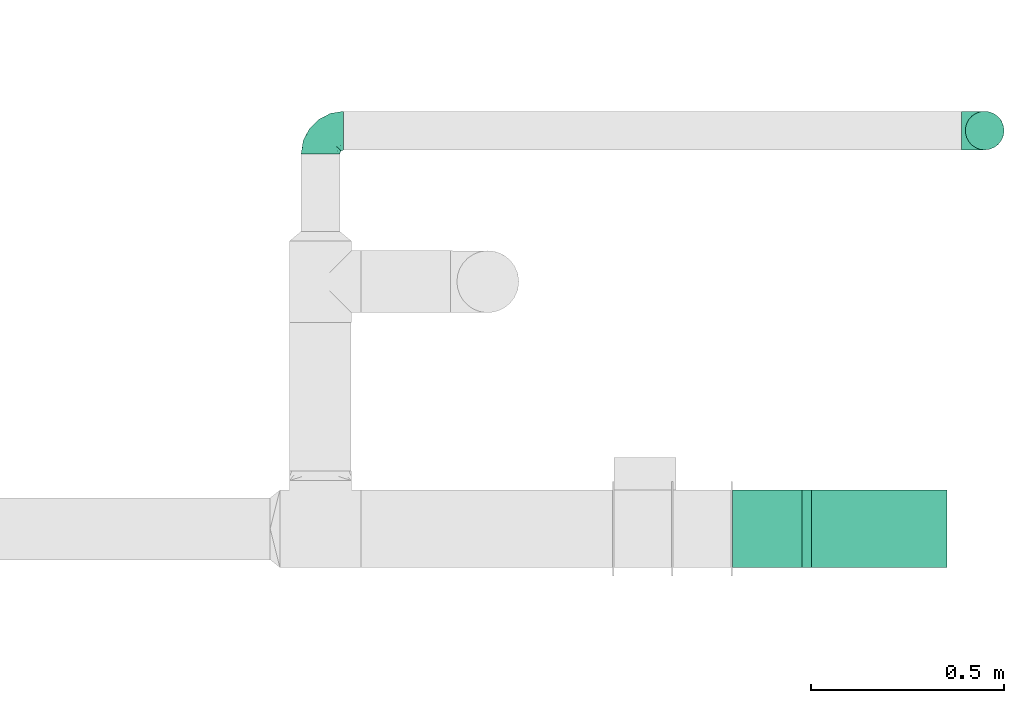
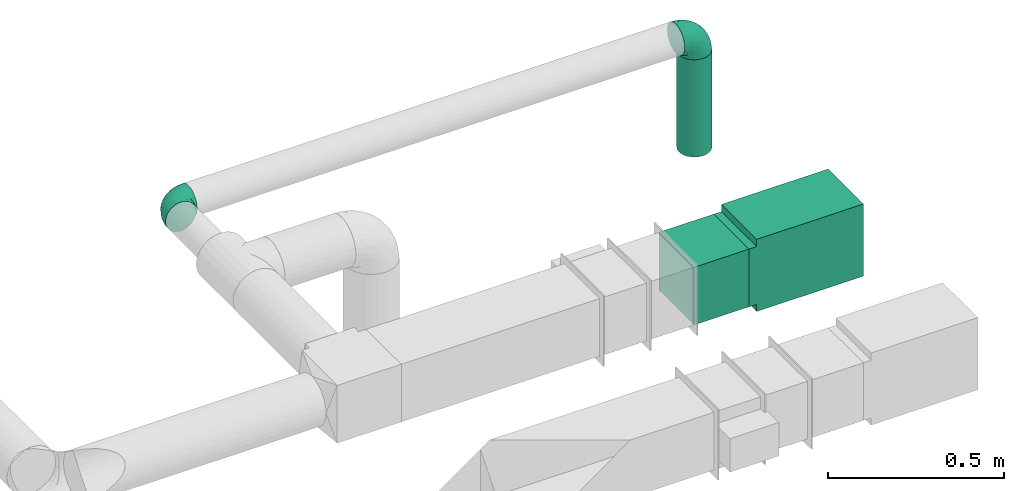
# One storey, part 11 of 12: 3 flow fittings, 2 flow segments.
"""IFC2X3 building model written with IfcOpenShell, lengths in millimetres."""

from ifc_helpers import new_model, entity, si_unit, converted_unit, derived_unit, direction, frame, frame_2d, origin, origin_2d_with_axis, place, context, subcontext, project, spatial, polyline, rectangle, circle, outline, extrude, faceted_brep, source, transform, mapped, type_object, type_shapes, element, save


model = new_model("IFC2X3")

# Units and contexts
model_context = context("Model", 3, precision=0.01, world=origin(), true_north=direction((6.12303176911189e-17, 1.0)))
body_context = subcontext(model_context, "Body", "Model", "MODEL_VIEW")
ifc_project = project(units=[si_unit("LENGTHUNIT", "METRE", prefix="MILLI"), si_unit("AREAUNIT", "SQUARE_METRE"), si_unit("VOLUMEUNIT", "CUBIC_METRE"), converted_unit("PLANEANGLEUNIT", "DEGREE", entity("IfcRatioMeasure", 0.0174532925199433), si_unit("PLANEANGLEUNIT", "RADIAN"), dimensions=[0, 0, 0, 0, 0, 0, 0]), si_unit("MASSUNIT", "GRAM", prefix="KILO"), derived_unit("MASSDENSITYUNIT", [(si_unit("MASSUNIT", "GRAM", prefix="KILO"), 1), (si_unit("LENGTHUNIT", "METRE"), -3)]), si_unit("TIMEUNIT", "SECOND"), si_unit("FREQUENCYUNIT", "HERTZ"), si_unit("THERMODYNAMICTEMPERATUREUNIT", "DEGREE_CELSIUS"), derived_unit("THERMALTRANSMITTANCEUNIT", [(si_unit("MASSUNIT", "GRAM", prefix="KILO"), 1), (si_unit("THERMODYNAMICTEMPERATUREUNIT", "KELVIN"), -1), (si_unit("TIMEUNIT", "SECOND"), -3)]), derived_unit("VOLUMETRICFLOWRATEUNIT", [(si_unit("LENGTHUNIT", "METRE"), 3), (si_unit("TIMEUNIT", "SECOND"), -1)]), si_unit("ELECTRICCURRENTUNIT", "AMPERE"), si_unit("ELECTRICVOLTAGEUNIT", "VOLT"), si_unit("POWERUNIT", "WATT"), si_unit("FORCEUNIT", "NEWTON", prefix="KILO"), si_unit("ILLUMINANCEUNIT", "LUX"), si_unit("LUMINOUSFLUXUNIT", "LUMEN"), si_unit("LUMINOUSINTENSITYUNIT", "CANDELA"), derived_unit("USERDEFINED", [(si_unit("MASSUNIT", "GRAM", prefix="KILO"), -1), (si_unit("LENGTHUNIT", "METRE"), -2), (si_unit("TIMEUNIT", "SECOND"), 3), (si_unit("LUMINOUSFLUXUNIT", "LUMEN"), 1)]), derived_unit("LINEARVELOCITYUNIT", [(si_unit("LENGTHUNIT", "METRE"), 1), (si_unit("TIMEUNIT", "SECOND"), -1)]), si_unit("PRESSUREUNIT", "PASCAL"), derived_unit("USERDEFINED", [(si_unit("LENGTHUNIT", "METRE"), -2), (si_unit("MASSUNIT", "GRAM", prefix="KILO"), 1), (si_unit("TIMEUNIT", "SECOND"), -2)])], contexts=[model_context])

# Site, building, storey
site_placement = place(None, origin())
site = spatial("IfcSite", under=ifc_project, at=site_placement, CompositionType="ELEMENT")
building_placement = place(site_placement, origin())
building = spatial("IfcBuilding", under=site, at=building_placement, CompositionType="ELEMENT")
storey_placement = place(building_placement, frame((0.0, 0.0, 8000.0)))
storey = spatial("IfcBuildingStorey", under=building, at=storey_placement, Name="02 Level", CompositionType="ELEMENT", Elevation=8000.0)

# Flow segments
duct_segment_type_1 = type_object("IfcDuctSegmentType", Name="Round Duct:Air", PredefinedType="NOTDEFINED")
flow_segment_1_placement = place(storey_placement, frame((24851.8947986159, -67528.1388300248, 2603.07847999992)))
element("IfcFlowSegment", 1, at=flow_segment_1_placement, inside=storey, type_object=duct_segment_type_1, Name="Round Duct:Air", ObjectType="Round Duct:Air", context=body_context, shape_type="SweptSolid", body=[
    extrude(circle(Radius=50.0, at=origin_2d_with_axis()), frame((51.5952722359175, 51.5952722359132, 0.0), z_axis=(0.0, 0.0, 1.0), x_axis=(0.0, 1.0, 0.0)), (0.0, 0.0, 1.0), 336.921519999948),
])
duct_segment_type_2 = type_object("IfcDuctSegmentType", Name="Rectangular Duct:Air", PredefinedType="NOTDEFINED")
flow_segment_2_placement = place(storey_placement, frame((24250.9900708518, -68606.4439409626, 2900.0)))
element("IfcFlowSegment", 2, at=flow_segment_2_placement, inside=storey, type_object=duct_segment_type_2, Name="Rectangular Duct:Air", ObjectType="Rectangular Duct:Air", context=body_context, shape_type="SweptSolid", body=[
    extrude(rectangle(XDim=179.671447124557, YDim=199.999999999998, at=frame_2d((0.0, -4.33431068813661e-12), x_axis=(1.0, 0.0))), frame((89.8357235622787, 100.0, 0.0)), (0.0, 0.0, 1.0), 200.000000000002),
])

# Flow fittings
duct_fitting_type_1 = type_object("IfcDuctFittingType", Name="Air_Elbow short_Circ", PredefinedType="NOTDEFINED")
shared_shape_1 = source(origin(), body_context, "Body", "Brep", [
    faceted_brep([(-60.0, -12.9409522551261, -48.2962913144533), (-60.0, -25.0, -43.3012701892219), (-60.0, -35.3553390593274, -35.3553390593273), (-60.0, -43.3012701892219, -25.0), (-60.0, -48.2962913144534, -12.940952255126), (-60.0, -50.0, 0.0), (-60.0, -48.2962913144533, 12.9409522551263), (-60.0, -43.3012701892217, 25.0), (-60.0, -35.3553390593271, 35.3553390593275), (-60.0, -25.0, 43.301270189222), (-60.0, -18.9704761275628, 45.7987807518377), (-60.0, -12.9409522551258, 48.2962913144534), (-60.0, 0.0, 50.0), (-60.0, 12.9409522551262, 48.2962913144533), (-60.0, 25.0, 43.3012701892218), (-60.0, 35.3553390593275, 35.3553390593272), (-60.0, 43.301270189222, 25.0), (-60.0, 48.2962913144534, 12.9409522551259), (-60.0, 50.0, 0.0), (-60.0, 48.2962913144533, -12.9409522551262), (-60.0, 43.3012701892218, -25.0), (-60.0, 35.3553390593273, -35.3553390593274), (-60.0, 25.0, -43.3012701892219), (-60.0, 12.9409522551259, -48.2962913144534), (-60.0, 0.0, -50.0), (0.0, -60.0, -50.0), (12.9409522551268, -60.0, -48.2962913144534), (25.0, -60.0, -43.3012701892219), (35.3553390593281, -60.0, -35.3553390593274), (43.3012701892227, -60.0, -25.0), (48.2962913144542, -60.0, -12.9409522551262), (50.0, -60.0, 0.0), (48.2962913144543, -60.0, 12.9409522551259), (43.3012701892229, -60.0, 25.0), (35.3553390593284, -60.0, 35.3553390593272), (25.0, -60.0, 43.3012701892218), (12.9409522551271, -60.0, 48.2962913144533), (0.0, -60.0, 50.0), (-12.9409522551249, -60.0, 48.2962913144534), (-25.0, -60.0, 43.301270189222), (-35.3553390593263, -60.0, 35.3553390593275), (-43.3012701892209, -60.0, 25.0), (-48.2962913144524, -60.0, 12.9409522551263), (-50.0, -60.0, 0.0), (-48.2962913144525, -60.0, -12.940952255126), (-43.301270189221, -60.0, -25.0), (-35.3553390593265, -60.0, -35.3553390593273), (-25.0, -60.0, -43.3012701892219), (-18.9704761275622, -60.0, -45.7987807518376), (-12.9409522551252, -60.0, -48.2962913144533), (-34.4613055182162, 40.2781615499549, 24.6893391361235), (-41.7413930879589, 46.3367006663211, 14.3622192349088), (-49.0564079906538, 40.7801415025898, 28.076858272246), (-43.0040653093767, 47.3081083962334, 0.0), (-46.9531334224505, -28.9691372331723, 42.5007483631415), (-49.945230570524, -14.009456366224, 48.3010541644054), (46.3367008388525, -41.7413924405609, 14.3622183025403), (-28.9195822317624, 34.3595042325614, 30.8522337271345), (-16.4026032888538, 28.8335615486346, 31.3447155376829), (-20.8886043148544, 37.032907476011, 22.5646988156665), (8.51327307359233, -29.8490270681828, 47.7425705251578), (21.5851347328685, -39.3600400603544, 43.7780030266717), (18.1051423029501, -18.6630708487668, 41.1725129713058), (-3.94145017646366, -44.1513377558611, 49.9695692624666), (-16.993357552601, -43.112835299455, 48.0588376259554), (-29.8490305613342, 8.51327565171467, 47.7425702287428), (-18.6630773197735, 18.1051465687322, 41.1725124591201), (-39.360041631582, 21.585137213725, 43.7780019122438), (-41.9572959526986, 32.3456520264411, 36.575294220854), (-28.3738768436699, 26.9110252548877, 38.0083212356069), (-47.8035915916317, -49.3365848090307, 24.1167211667097), (-51.9080682539527, -51.9080682564403, 11.9284381035673), (-28.9388870718402, -47.4392187660381, 42.4028289139121), (-46.4119732313288, 8.97786791845547, 48.9268647037242), (15.3655862372502, 1.44443599762982, 33.3656926605527), (12.7026747916207, 16.0653579926251, 21.330563165355), (-0.0901680697707372, 16.249793899354, 33.6631038709893), (-26.0984306641832, -9.4519602521943, 49.9925353018775), (-43.5357165770215, -3.92607608695299, 49.9756911723036), (-40.3512409746586, -17.2001159603688, 48.3058104561749), (-51.5116032222349, -38.9116886125261, 33.3337470302399), (40.2781623134548, -34.4613024546835, 24.689336501659), (34.3595052098631, -28.9195768148052, 30.852230382061), (32.3456522233896, -41.9572963751397, 36.5752941161915), (-52.6192947824697, -44.3162483434043, 26.0687788699409), (8.97786691245749, -46.4119718726044, 48.9268648562795), (35.0507691245895, -17.8379542600364, 23.7817320689175), (-0.154113830211583, 27.0441585303382, 20.4371969134619), (0.164802122834046, 30.9507973718637, 9.70158150296541), (-10.9191638901366, 35.9593562872322, 14.7243484546897), (40.7801421145919, -49.0564069362065, 28.0768572079665), (42.5446020921407, -25.3772134428819, 13.1791087429088), (23.1044280783399, 10.2139010010231, 10.911201952746), (10.303795037543, 23.1674391280597, 10.425151792526), (47.3081083962343, -43.0040653093781, 0.0), (44.6162167924678, -26.008130618756, 0.0), (-32.7984308187714, -33.1644722725009, 45.0025999357929), (-41.6246972537655, -41.624696659769, 36.6481760707585), (-16.0198594588589, -0.790040969679908, 48.0702532559686), (-7.74597844975689, -15.8760781607658, 49.2907901610601), (-10.2505184648613, -32.0701285913551, 49.9130990257927), (-52.9289321881336, -52.9289321881345, 0.0), (-38.9116885130941, -51.5116028691678, 33.3337472807585), (27.3373523634918, -28.9262874076833, 37.8242669720924), (28.8335585354312, -16.4025932897411, 31.3447134244473), (-10.6758764332908, 36.8040430868554, 0.0), (-21.0820556464647, -25.013405385062, 49.4085637061446), (-25.3772163464242, 42.5446022063287, 13.179111746218), (-29.4708300504911, -18.1716321771538, 49.3204506255928), (-0.613576836584022, -32.0726800049485, 49.6825501479137), (-26.0081306187546, 44.6162167924668, 0.0), (-1.21981718883359, -1.21981162112378, 44.3295369128094), (7.809323786389, -12.5506490133832, 44.518448707346), (4.65637775217312, 28.991869381244, 0.0), (30.9271083665945, 0.192011278925337, 9.72551394481069), (25.4694098156993, 0.899564345657441, 21.9045256717261), (36.8040430868565, -10.6758764332921, 0.0), (8.17237141004653, -0.709602060124845, 39.7363553078916), (-1.20691178924098, 8.42774890414073, 39.8368437988478), (-11.8311378719951, 8.12805454147699, 44.1670059112514), (16.8241235667092, 16.8241235667079, 0.0), (35.9593546638031, -10.9191599029529, 14.7243472530362), (28.9918693812452, 4.65637775217184, 0.0), (-14.0094588862512, -49.9452236085703, -48.3010539035587), (-25.3772156484835, 42.5446019119684, -13.1791119497906), (-34.4613048910139, 40.2781614393135, -24.6893390523416), (-41.7413926252934, 46.3367005832334, -14.3622192468898), (-43.1128355702084, -16.9933564311214, -48.0588378972243), (-44.1513388294639, -3.94144876101963, -49.969569299814), (-51.5116035577561, -38.9116884747343, -33.3337470330805), (-41.62469790636, -41.6246960630329, -36.6481760341003), (-49.3365851024771, -47.8035917204495, -24.1167206397972), (16.0653446591387, 12.7026862735946, -21.330566780897), (10.2138986720569, 23.1044286164337, -10.9112068363266), (23.1674375203698, 10.3037953844737, -10.4251565011195), (27.0441512446144, -0.154114142874967, -20.4372107139949), (30.9507965291521, 0.164803474452689, -9.70158128624016), (35.9593546209329, -10.9191616413996, -14.7243499458666), (-28.9262923378956, 27.3373567288812, -37.8242648451571), (-16.4026019873643, 28.8335613017021, -31.344715100551), (-18.6630757642047, 18.1051470727615, -41.1725116507822), (-0.79004904716724, -16.0198534732482, -48.0702540902608), (-9.45196719952168, -26.0984311316614, -49.9925354060889), (-15.8760743141415, -7.74597807562093, -49.2907896898935), (-25.0134056140136, -21.0820528609103, -49.4085640038716), (-49.0564077792961, 40.7801415002595, -28.0768582420378), (-33.1644687800828, -32.7984277324913, -45.0026021871039), (-47.4392196421628, -28.9388866268174, -42.4028289664685), (-51.9080682748156, -51.9080682458111, -11.9284380741106), (-39.3600407942016, 21.5851376014369, -43.7780015915287), (-41.9572952892088, 32.3456521258773, -36.5752940113004), (-29.8490289400598, 8.5132766456386, -47.7425697425162), (-46.411972568153, 8.97786849540185, -48.9268645575236), (-17.8379596675892, 35.0507702162708, -23.7817342784206), (-28.9195813138317, 34.3595041939927, -30.8522334076151), (18.1051443153088, -18.6630730295509, -41.1725124486671), (26.9110256448416, -28.3738769796432, -38.0083209621406), (21.5851368100191, -39.3600388626355, -43.7780017534797), (-44.316248159738, -52.6192941440622, -26.0687795868405), (-38.911688364674, -51.5116023985273, -33.3337476311683), (-3.92607321834031, -43.5357049838062, -49.9756913600445), (-17.2001201011705, -40.3512365316697, -48.3058099460363), (8.97786798225732, -46.4119703958823, -48.9268645751331), (8.51327412363391, -29.8490256018375, -47.7425700423665), (40.7801413413476, -49.0564079294803, -28.0768584987253), (-28.969136268001, -46.9531365639949, -42.5007481599507), (1.44442453081588, 15.3655954628303, -33.3656927670723), (16.2497893015437, -0.0901603719773552, -33.6631026184802), (32.3456517066656, -41.9572939682546, -36.5752941586943), (46.3367004266908, -41.7413922128929, -14.3622195286513), (28.8335602968518, -16.402602640196, -31.3447165791004), (37.0329066484517, -20.888602858321, -22.564699256686), (34.3595039081184, -28.9195810717321, -30.8522336573022), (40.2781610753798, -34.461304879185, -24.6893396682814), (-32.0701289123428, -10.2505155181949, -49.9130991682027), (42.5446013435109, -25.3772148558883, -13.1791129929581), (-18.17163862849, -29.4708285244359, -49.3204499074468), (-32.0726819537407, -0.61357350659226, -49.6825499006192), (-1.21981337419447, -1.21981084831843, -44.3295352204376), (-12.5506417422758, 7.80933382246174, -44.5184423716321), (0.192009591001318, 30.9271092740971, -9.72551482732434), (0.899550937376629, 25.4694163362272, -21.9045307406697), (-0.709596078235449, 8.17237239935393, -39.7363517396473), (8.42775025848031, -1.2069144200305, -39.8368443201002), (8.12805004108825, -11.8311369938791, -44.1670075921659), (-10.9191629014402, 35.9593557213529, -14.724348628576)], [[[0, 1, 2, 3, 4, 5, 6, 7, 8, 9, 10, 11, 12, 13, 14, 15, 16, 17, 18, 19, 20, 21, 22, 23, 24]], [[25, 26, 27, 28, 29, 30, 31, 32, 33, 34, 35, 36, 37, 38, 39, 40, 41, 42, 43, 44, 45, 46, 47, 48, 49]], [[50, 51, 52]], [[18, 17, 53]], [[9, 54, 55]], [[32, 56, 33]], [[57, 58, 59]], [[60, 61, 62]], [[63, 64, 38]], [[65, 66, 67]], [[67, 68, 14]], [[68, 69, 57]], [[42, 70, 71]], [[52, 16, 15]], [[64, 72, 39]], [[73, 13, 12]], [[74, 75, 76]], [[55, 11, 10, 9]], [[77, 78, 79]], [[67, 14, 13]], [[17, 16, 51]], [[7, 80, 8]], [[81, 82, 83]], [[7, 84, 80]], [[8, 54, 9]], [[72, 40, 39]], [[5, 71, 6]], [[73, 65, 67]], [[85, 37, 36]], [[7, 6, 84]], [[85, 36, 61]], [[81, 86, 82]], [[87, 88, 89]], [[35, 61, 36]], [[33, 90, 34]], [[38, 37, 63]], [[91, 81, 56]], [[90, 33, 56]], [[35, 83, 61]], [[75, 92, 93]], [[94, 95, 56]], [[96, 97, 72]], [[98, 77, 99]], [[64, 63, 100]], [[71, 5, 101]], [[68, 15, 14]], [[43, 71, 101]], [[66, 69, 67]], [[70, 102, 97]], [[103, 104, 62]], [[40, 102, 41]], [[105, 89, 88]], [[70, 42, 41]], [[96, 72, 64]], [[77, 106, 99]], [[64, 39, 38]], [[78, 12, 11]], [[59, 89, 107]], [[35, 34, 83]], [[91, 86, 81]], [[51, 53, 17]], [[56, 32, 94]], [[12, 78, 73]], [[106, 77, 108]], [[96, 108, 79]], [[97, 54, 80]], [[40, 72, 102]], [[96, 54, 97]], [[106, 64, 100]], [[85, 109, 63]], [[61, 83, 103]], [[81, 83, 90]], [[15, 68, 52]], [[50, 68, 57]], [[77, 65, 78]], [[53, 51, 110]], [[94, 32, 31]], [[65, 77, 98]], [[111, 99, 112]], [[63, 109, 100]], [[107, 51, 50]], [[93, 113, 88]], [[114, 92, 115]], [[74, 62, 104]], [[115, 74, 104]], [[91, 95, 116]], [[112, 117, 111]], [[115, 75, 74]], [[117, 118, 111]], [[111, 118, 119]], [[58, 66, 76]], [[111, 119, 98]], [[87, 58, 76]], [[118, 117, 74]], [[54, 96, 79]], [[106, 96, 64]], [[120, 113, 93]], [[86, 121, 115]], [[122, 92, 114]], [[120, 92, 122]], [[115, 92, 75]], [[120, 93, 92]], [[87, 75, 93]], [[75, 87, 76]], [[58, 87, 59]], [[37, 85, 63]], [[60, 85, 61]], [[13, 73, 67]], [[65, 73, 78]], [[107, 110, 51]], [[121, 116, 114]], [[116, 121, 91]], [[91, 56, 95]], [[41, 102, 70]], [[97, 102, 72]], [[8, 80, 54]], [[70, 97, 84]], [[100, 99, 106]], [[60, 99, 109]], [[100, 109, 99]], [[60, 109, 85]], [[93, 88, 87]], [[89, 105, 107]], [[80, 84, 97]], [[71, 70, 84]], [[84, 6, 71]], [[42, 71, 43]], [[16, 52, 51]], [[50, 52, 68]], [[34, 90, 83]], [[81, 90, 56]], [[79, 78, 55]], [[11, 55, 78]], [[54, 79, 55]], [[61, 103, 62]], [[104, 103, 82]], [[83, 82, 103]], [[104, 82, 86]], [[104, 86, 115]], [[91, 121, 86]], [[50, 57, 59]], [[58, 57, 69]], [[58, 69, 66]], [[67, 69, 68]], [[50, 59, 107]], [[87, 89, 59]], [[106, 108, 96]], [[108, 77, 79]], [[66, 65, 119]], [[111, 98, 99]], [[98, 119, 65]], [[76, 66, 118]], [[119, 118, 66]], [[76, 118, 74]], [[117, 62, 74]], [[62, 117, 112]], [[112, 60, 62]], [[60, 112, 99]], [[110, 107, 105]], [[105, 88, 113]], [[122, 114, 116]], [[121, 114, 115]], [[49, 48, 47, 123]], [[124, 125, 126]], [[0, 127, 1]], [[128, 0, 24]], [[129, 130, 131]], [[132, 133, 134]], [[2, 129, 3]], [[135, 136, 137]], [[131, 4, 3]], [[138, 139, 140]], [[141, 142, 143]], [[143, 142, 144]], [[145, 20, 126]], [[146, 130, 147]], [[53, 110, 126]], [[4, 131, 148]], [[149, 22, 150]], [[151, 149, 140]], [[22, 149, 23]], [[146, 147, 127]], [[147, 2, 1]], [[21, 20, 145]], [[150, 22, 21]], [[149, 152, 23]], [[125, 153, 154]], [[125, 154, 150]], [[148, 101, 5]], [[124, 153, 125]], [[148, 44, 43]], [[155, 156, 157]], [[158, 159, 45]], [[157, 27, 26]], [[116, 137, 136]], [[45, 159, 46]], [[1, 127, 147]], [[142, 160, 161]], [[162, 163, 157]], [[164, 29, 28]], [[165, 47, 46]], [[166, 132, 167]], [[25, 162, 26]], [[27, 157, 168]], [[128, 127, 0]], [[30, 29, 169]], [[170, 171, 172]], [[155, 157, 163]], [[152, 24, 23]], [[169, 164, 173]], [[160, 25, 49]], [[30, 94, 31]], [[168, 28, 27]], [[127, 128, 174]], [[168, 156, 172]], [[47, 165, 123]], [[19, 126, 20]], [[169, 94, 30]], [[5, 4, 148]], [[171, 137, 175]], [[45, 44, 158]], [[126, 19, 53]], [[25, 160, 162]], [[144, 142, 176]], [[146, 176, 161]], [[130, 165, 159]], [[2, 147, 129]], [[146, 165, 130]], [[144, 127, 174]], [[152, 177, 128]], [[149, 150, 138]], [[125, 150, 145]], [[28, 168, 164]], [[173, 168, 172]], [[142, 163, 160]], [[94, 169, 95]], [[53, 19, 18]], [[163, 142, 141]], [[178, 143, 179]], [[128, 177, 174]], [[175, 169, 173]], [[134, 122, 136]], [[180, 133, 181]], [[166, 140, 139]], [[181, 166, 139]], [[124, 110, 105]], [[179, 182, 178]], [[181, 132, 166]], [[182, 183, 178]], [[178, 183, 184]], [[170, 155, 167]], [[178, 184, 141]], [[135, 170, 167]], [[183, 182, 166]], [[165, 146, 161]], [[144, 146, 127]], [[120, 122, 134]], [[153, 185, 181]], [[113, 133, 180]], [[120, 133, 113]], [[181, 133, 132]], [[120, 134, 133]], [[135, 132, 134]], [[132, 135, 167]], [[170, 135, 171]], [[24, 152, 128]], [[151, 152, 149]], [[26, 162, 157]], [[163, 162, 160]], [[175, 95, 169]], [[185, 105, 180]], [[105, 185, 124]], [[124, 126, 110]], [[3, 129, 131]], [[130, 129, 147]], [[46, 159, 165]], [[131, 130, 158]], [[174, 143, 144]], [[151, 143, 177]], [[174, 177, 143]], [[151, 177, 152]], [[134, 136, 135]], [[137, 116, 175]], [[159, 158, 130]], [[148, 131, 158]], [[101, 148, 43]], [[158, 44, 148]], [[29, 164, 169]], [[173, 164, 168]], [[21, 145, 150]], [[125, 145, 126]], [[161, 160, 123]], [[49, 123, 160]], [[165, 161, 123]], [[149, 138, 140]], [[139, 138, 154]], [[150, 154, 138]], [[139, 154, 153]], [[139, 153, 181]], [[124, 185, 153]], [[173, 172, 171]], [[170, 172, 156]], [[170, 156, 155]], [[157, 156, 168]], [[173, 171, 175]], [[135, 137, 171]], [[144, 176, 146]], [[176, 142, 161]], [[155, 163, 184]], [[178, 141, 143]], [[141, 184, 163]], [[167, 155, 183]], [[184, 183, 155]], [[167, 183, 166]], [[182, 140, 166]], [[140, 182, 179]], [[179, 151, 140]], [[151, 179, 143]], [[95, 175, 116]], [[116, 136, 122]], [[113, 180, 105]], [[185, 180, 181]]]),
])
type_shapes(duct_fitting_type_1, [shared_shape_1])
for number, where, z_axis, x_axis, name in (
    (3, (24903.4900708518, -67476.5435577884, 3000.0), (0.0, 1.0, 0.0), (0.0, 0.0, 1.0), "elbow_short_001:Air_Elbow short_Circ"),
    (4, (23185.9900708518, -67476.5435577883, 3000.0), (0.0, 0.0, 1.0), (0.0, 1.0, 0.0), "elbow_short_001:Air_Elbow short_Circ"),
):
    element("IfcFlowFitting", number, at=place(storey_placement, frame(where, z_axis=z_axis, x_axis=x_axis)), inside=storey, type_object=duct_fitting_type_1, Name=name, ObjectType="elbow_short_001:Air_Elbow short_Circ", context=body_context, shape_type="MappedRepresentation", body=[
        mapped(shared_shape_1, transform((0.0, 0.0, 0.0), scale=1.0)),
    ])
duct_fitting_type_2 = type_object("IfcDuctFittingType", Name="Air_Rect", PredefinedType="NOTDEFINED")
shared_shape_2 = source(origin(), body_context, "Body", "SweptSolid", [
    extrude(outline(polyline([(-81.2499999999996, -125.0), (268.75, -125.0), (268.75, 125.0), (-81.2500000000004, 125.0), (-81.2500000000003, 100.0), (-106.25, 100.0), (-106.25, -100.0), (-81.2499999999997, -100.0), (-81.2499999999996, -125.0)])), frame((0.0, 93.75, -100.0), z_axis=(0.0, 0.0, 1.0), x_axis=(0.0, -1.0, 0.0)), (0.0, 0.0, 1.0), 200.0),
])
type_shapes(duct_fitting_type_2, [shared_shape_2])
flow_fitting_placement = place(storey_placement, frame((24630.6615179764, -68506.4439409627, 3000.0), z_axis=(0.0, 1.0, 0.0), x_axis=(0.0, 0.0, -1.0)))
element("IfcFlowFitting", 5, at=flow_fitting_placement, inside=storey, type_object=duct_fitting_type_2, Name="1_001:Air_Rect", ObjectType="1_001:Air_Rect", context=body_context, shape_type="MappedRepresentation", body=[
    mapped(shared_shape_2, transform((0.0, 0.0, 0.0), scale=1.0)),
])

save(model, "model.ifc")
